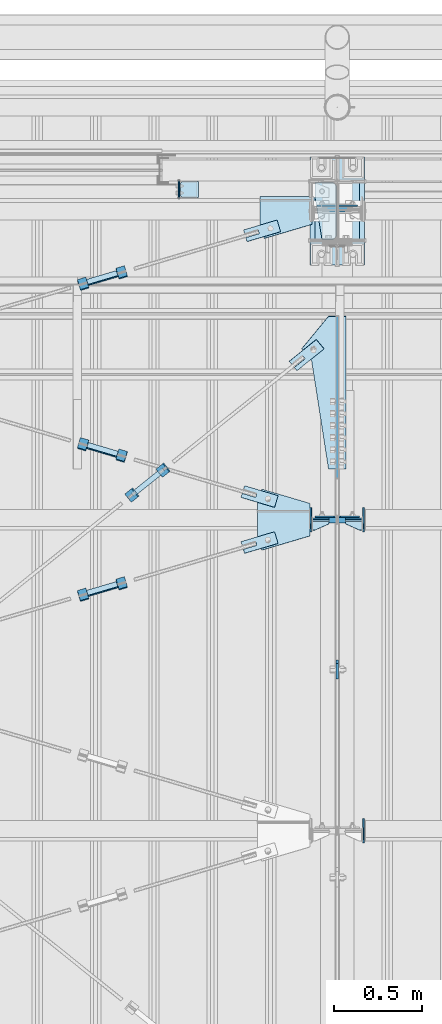
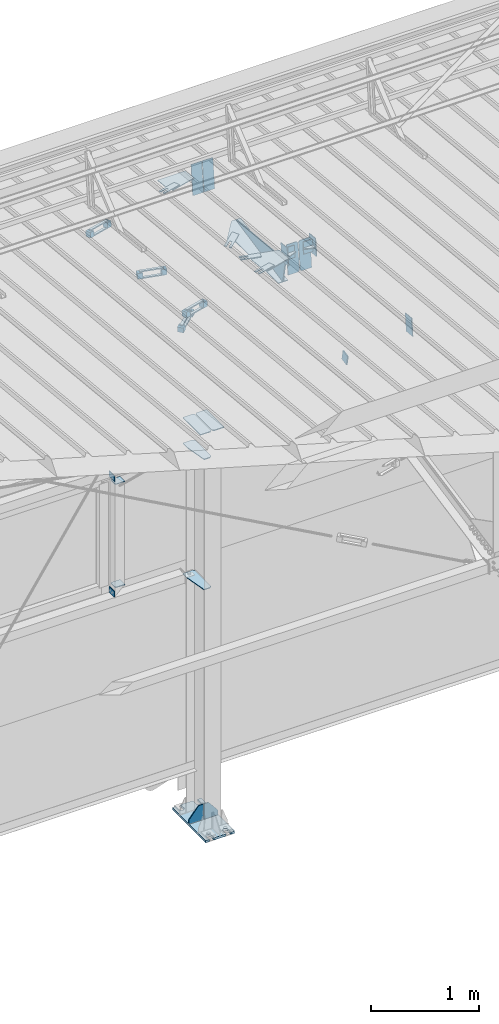
# One storey, part 135 of 709: 47 plates, 7 openings, 18 elements without a shape of their own.
"""IFC4 building model written with IfcOpenShell, lengths in millimetres."""

from ifc_helpers import new_model, si_unit, direction, frame, origin_with_axes, place, context, subcontext, project, spatial, line, arc, indexed_curve, outline, extrude, material, element, aggregate, save


model = new_model("IFC4")

# Units and contexts
model_context = context("Model", 3, precision=0.2, world=origin_with_axes(), true_north=direction((0.0, 1.0)))
body_context = subcontext(model_context, "Body", "Model", "MODEL_VIEW")
ifc_project = project(units=[si_unit("LENGTHUNIT", "METRE", prefix="MILLI"), si_unit("AREAUNIT", "SQUARE_METRE"), si_unit("VOLUMEUNIT", "CUBIC_METRE"), si_unit("MASSUNIT", "GRAM", prefix="KILO"), si_unit("TIMEUNIT", "SECOND"), si_unit("PLANEANGLEUNIT", "RADIAN"), si_unit("SOLIDANGLEUNIT", "STERADIAN"), si_unit("THERMODYNAMICTEMPERATUREUNIT", "DEGREE_CELSIUS"), si_unit("LUMINOUSINTENSITYUNIT", "LUMEN")], contexts=[model_context])

# Site, building, storey
site_placement = place(None, origin_with_axes())
site = spatial("IfcSite", under=ifc_project, at=site_placement, CompositionType="ELEMENT")
building_placement = place(site_placement, origin_with_axes())
building = spatial("IfcBuilding", under=site, at=building_placement, Name="Undefined", CompositionType="ELEMENT")
storey_placement = place(building_placement, origin_with_axes())
storey = spatial("IfcBuildingStorey", under=building, at=storey_placement, Name="Undefined", CompositionType="ELEMENT", Elevation=0.0)

# Assembly, plates, voiding features
assembly_1_placement = place(storey_placement, frame((10000.0, 21827.0, -200.0), z_axis=(-1.0, 0.0, 0.0), x_axis=(0.0, 0.0, 1.0)))
assembly_1 = element("IfcElementAssembly", 1, at=assembly_1_placement, inside=storey)
ifc_material_1 = material(Name="C355-6", Category="STEEL")
plate_1_placement = place(assembly_1_placement, frame((7434.21546, 30.02526, -3.0), z_axis=(-0.099503719, 0.9950371902, 0.0), x_axis=(0.0, 0.0, -1.0)))
plate_1 = element("IfcPlate", 2, at=plate_1_placement, material=ifc_material_1, ObjectType="595", context=body_context, shape_type="SolidModel", body=[
    extrude(outline(indexed_curve([(0.0, 0.0), (114.0, 0.0), (114.0, 333.33554), (0.0, 333.33554)], segments=[line(1, 2, 3, 4, 1)])), frame((0.0, 0.0, 4.0), z_axis=(0.0, 0.0, 1.0), x_axis=(1.0, 0.0, 0.0)), (0.0, 0.0, -1.0), 8.0),
])
plate_2_placement = place(assembly_1_placement, frame((7434.21546, 30.02526, 3.0), z_axis=(0.099503719, -0.9950371902, 0.0), x_axis=(0.0, 0.0, 1.0)))
plate_2 = element("IfcPlate", 3, at=plate_2_placement, material=ifc_material_1, ObjectType="595", context=body_context, shape_type="SolidModel", body=[
    extrude(outline(indexed_curve([(0.0, 0.0), (114.0, 0.0), (114.0, 332.53554), (0.0, 332.53554)], segments=[line(1, 2, 3, 4, 1)])), frame((0.0, 0.0, 4.0), z_axis=(0.0, 0.0, 1.0), x_axis=(1.0, 0.0, 0.0)), (0.0, 0.0, -1.0), 8.0),
])
plate_3_placement = place(assembly_1_placement, frame((4212.0, 163.0, 4.0), z_axis=(1.0, 0.0, 0.0), x_axis=(0.0, 0.0, 1.0)))
plate_3 = element("IfcPlate", 4, at=plate_3_placement, material=ifc_material_1, ObjectType="543", context=body_context, shape_type="SolidModel", body=[
    extrude(outline(indexed_curve([(0.0, 20.0), (20.0, 0.0), (123.0, 0.0), (123.0, 86.0), (83.0, 326.0), (20.0, 326.0), (0.0, 306.0)], segments=[line(1, 2, 3, 4, 5, 6, 7, 1)])), frame((0.0, 0.0, 4.0), z_axis=(0.0, 0.0, 1.0), x_axis=(1.0, 0.0, 0.0)), (0.0, 0.0, -1.0), 8.0),
])
plate_4_placement = place(assembly_1_placement, frame((4502.0, 163.0, 127.0), z_axis=(-1.0, 0.0, 0.0), x_axis=(0.0, 0.0, -1.0)))
plate_4 = element("IfcPlate", 5, at=plate_4_placement, material=ifc_material_1, ObjectType="547", context=body_context, shape_type="SolidModel", body=[
    extrude(outline(indexed_curve([(0.0, 0.0), (108.0, 0.0), (123.0, 15.0), (123.0, 311.0), (108.0, 326.0), (0.0, 326.0)], segments=[line(1, 2, 3, 4, 5, 6, 1)])), frame((0.0, 0.0, 4.0), z_axis=(0.0, 0.0, 1.0), x_axis=(1.0, 0.0, 0.0)), (0.0, 0.0, -1.0), 8.0),
])
plate_5_placement = place(assembly_1_placement, frame((2742.0, 163.0, 4.0), z_axis=(1.0, 0.0, 0.0), x_axis=(0.0, 0.0, 1.0)))
plate_5 = element("IfcPlate", 6, at=plate_5_placement, material=ifc_material_1, ObjectType="543", context=body_context, shape_type="SolidModel", body=[
    extrude(outline(indexed_curve([(0.0, 20.0), (20.0, 0.0), (123.0, 0.0), (123.0, 86.0), (83.0, 326.0), (20.0, 326.0), (0.0, 306.0)], segments=[line(1, 2, 3, 4, 5, 6, 7, 1)])), frame((0.0, 0.0, 4.0), z_axis=(0.0, 0.0, 1.0), x_axis=(1.0, 0.0, 0.0)), (0.0, 0.0, -1.0), 8.0),
])
plate_6_placement = place(assembly_1_placement, frame((4502.0, -163.0, -127.0), z_axis=(-1.0, 0.0, 0.0), x_axis=(0.0, 0.0, 1.0)))
plate_6 = element("IfcPlate", 7, at=plate_6_placement, material=ifc_material_1, ObjectType="547", context=body_context, shape_type="SolidModel", body=[
    extrude(outline(indexed_curve([(0.0, 0.0), (108.0, 0.0), (123.0, 15.0), (123.0, 311.0), (108.0, 326.0), (0.0, 326.0)], segments=[line(1, 2, 3, 4, 5, 6, 1)])), frame((0.0, 0.0, 4.0), z_axis=(0.0, 0.0, 1.0), x_axis=(1.0, 0.0, 0.0)), (0.0, 0.0, -1.0), 8.0),
])
plate_7_placement = place(assembly_1_placement, frame((25.0, 0.0, 3.0), z_axis=(0.0, 1.0, 0.0), x_axis=(0.0, 0.0, 1.0)))
plate_7 = element("IfcPlate", 8, at=plate_7_placement, material=ifc_material_1, ObjectType="417", context=body_context, shape_type="SolidModel", body=[
    extrude(outline(indexed_curve([(0.0, 0.0), (152.0, 0.0), (152.0, 50.0), (50.0, 175.0), (0.0, 175.0)], segments=[line(1, 2, 3, 4, 5, 1)])), frame((0.0, 0.0, 4.0), z_axis=(0.0, 0.0, 1.0), x_axis=(1.0, 0.0, 0.0)), (0.0, 0.0, -1.0), 8.0),
])
plate_8_placement = place(assembly_1_placement, frame((25.0, 0.0, -3.0), z_axis=(0.0, -1.0, 0.0), x_axis=(0.0, 0.0, -1.0)))
plate_8 = element("IfcPlate", 9, at=plate_8_placement, material=ifc_material_1, ObjectType="417", context=body_context, shape_type="SolidModel", body=[
    extrude(outline(indexed_curve([(0.0, 0.0), (152.0, 0.0), (152.0, 50.0), (50.0, 175.0), (0.0, 175.0)], segments=[line(1, 2, 3, 4, 5, 1)])), frame((0.0, 0.0, 4.0), z_axis=(0.0, 0.0, 1.0), x_axis=(1.0, 0.0, 0.0)), (0.0, 0.0, -1.0), 8.0),
])
plate_9_placement = place(assembly_1_placement, frame((12.5, -308.0, 155.0), z_axis=(1.0, 0.0, 0.0), x_axis=(0.0, 0.0, -1.0)))
plate_9 = element("IfcPlate", 10, at=plate_9_placement, material=ifc_material_1, ObjectType="416", context=body_context, shape_type="SolidModel", body=[
    extrude(outline(indexed_curve([(0.0, 0.0), (310.0, 0.0), (310.0, 616.0), (0.0, 616.0)], segments=[line(1, 2, 3, 4, 1)])), frame((0.0, 0.0, 12.5), z_axis=(0.0, 0.0, 1.0), x_axis=(1.0, 0.0, 0.0)), (0.0, 0.0, -1.0), 25.0),
])
voiding_feature_1_placement = place(plate_9_placement, frame((40.0, 616.0, 0.0), z_axis=(0.0, 0.0, -1.0), x_axis=(1.0, 0.0, 0.0)))
element("IfcVoidingFeature", 11, at=voiding_feature_1_placement, cuts=plate_9, PredefinedType="HOLE", context=body_context, shape_type="SolidModel", body=[
    extrude(outline(indexed_curve([(0.0, 0.0), (50.0, 0.0), (50.0, 60.0), (42.67767, 77.67767), (25.0, 85.0), (25.0, 85.0), (7.32233, 77.67767), (0.0, 60.0)], segments=[line(1, 2, 3), arc(3, 4, 5), line(5, 6), arc(6, 7, 8), line(8, 1)])), frame((0.0, 0.0, 12.5), z_axis=(0.0, 0.0, 1.0), x_axis=(1.0, 0.0, 0.0)), (0.0, 0.0, -1.0), 25.0),
])
voiding_feature_2_placement = place(plate_9_placement, frame((40.0, 0.0, 0.0), z_axis=(0.0, 0.0, 1.0), x_axis=(1.0, 0.0, 0.0)))
element("IfcVoidingFeature", 12, at=voiding_feature_2_placement, cuts=plate_9, PredefinedType="HOLE", context=body_context, shape_type="SolidModel", body=[
    extrude(outline(indexed_curve([(0.0, 0.0), (50.0, 0.0), (50.0, 60.0), (42.67767, 77.67767), (25.0, 85.0), (25.0, 85.0), (7.32233, 77.67767), (0.0, 60.0)], segments=[line(1, 2, 3), arc(3, 4, 5), line(5, 6), arc(6, 7, 8), line(8, 1)])), frame((0.0, 0.0, 12.5), z_axis=(0.0, 0.0, 1.0), x_axis=(1.0, 0.0, 0.0)), (0.0, 0.0, -1.0), 25.0),
])
voiding_feature_3_placement = place(plate_9_placement, frame((270.0, 616.0, 0.0), z_axis=(0.0, 0.0, 1.0), x_axis=(-1.0, 0.0, 0.0)))
element("IfcVoidingFeature", 13, at=voiding_feature_3_placement, cuts=plate_9, PredefinedType="HOLE", context=body_context, shape_type="SolidModel", body=[
    extrude(outline(indexed_curve([(0.0, 0.0), (50.0, 0.0), (50.0, 60.0), (42.67767, 77.67767), (25.0, 85.0), (25.0, 85.0), (7.32233, 77.67767), (0.0, 60.0)], segments=[line(1, 2, 3), arc(3, 4, 5), line(5, 6), arc(6, 7, 8), line(8, 1)])), frame((0.0, 0.0, 12.5), z_axis=(0.0, 0.0, 1.0), x_axis=(1.0, 0.0, 0.0)), (0.0, 0.0, -1.0), 25.0),
])
voiding_feature_4_placement = place(plate_9_placement, frame((270.0, 0.0, 0.0), z_axis=(0.0, 0.0, -1.0), x_axis=(-1.0, 0.0, 0.0)))
element("IfcVoidingFeature", 14, at=voiding_feature_4_placement, cuts=plate_9, PredefinedType="HOLE", context=body_context, shape_type="SolidModel", body=[
    extrude(outline(indexed_curve([(0.0, 0.0), (50.0, 0.0), (50.0, 60.0), (42.67767, 77.67767), (25.0, 85.0), (25.0, 85.0), (7.32233, 77.67767), (0.0, 60.0)], segments=[line(1, 2, 3), arc(3, 4, 5), line(5, 6), arc(6, 7, 8), line(8, 1)])), frame((0.0, 0.0, 12.5), z_axis=(0.0, 0.0, 1.0), x_axis=(1.0, 0.0, 0.0)), (0.0, 0.0, -1.0), 25.0),
])
aggregate(assembly_1, [plate_1, plate_2, plate_3, plate_4, plate_5, plate_6, plate_7, plate_8, plate_9])

# Assembly, plates
assembly_2_placement = place(storey_placement, frame((10000.0, 21654.0, 7089.70002), z_axis=(-1.0, 0.0, 0.0), x_axis=(0.0, -0.9950371902, 0.099503719)))
assembly_2 = element("IfcElementAssembly", 15, at=assembly_2_placement, inside=storey)
plate_10_placement = place(assembly_2_placement, frame((1597.88359, 163.0, -127.0), z_axis=(1.0, 0.0, 0.0), x_axis=(0.0, 0.0, 1.0)))
plate_10 = element("IfcPlate", 16, at=plate_10_placement, material=ifc_material_1, ObjectType="585", context=body_context, shape_type="SolidModel", body=[
    extrude(outline(indexed_curve([(0.0, 0.0), (108.0, 0.0), (123.0, 15.0), (123.0, 311.0), (108.0, 326.0), (0.0, 326.0)], segments=[line(1, 2, 3, 4, 5, 6, 1)])), frame((0.0, 0.0, 4.0), z_axis=(0.0, 0.0, 1.0), x_axis=(1.0, 0.0, 0.0)), (0.0, 0.0, -1.0), 8.0),
])
plate_11_placement = place(assembly_2_placement, frame((1597.88359, 163.0, 127.0), z_axis=(-1.0, 0.0, 0.0), x_axis=(0.0, 0.0, -1.0)))
plate_11 = element("IfcPlate", 17, at=plate_11_placement, material=ifc_material_1, ObjectType="585", context=body_context, shape_type="SolidModel", body=[
    extrude(outline(indexed_curve([(0.0, 0.0), (108.0, 0.0), (123.0, 15.0), (123.0, 311.0), (108.0, 326.0), (0.0, 326.0)], segments=[line(1, 2, 3, 4, 5, 6, 1)])), frame((0.0, 0.0, 4.0), z_axis=(0.0, 0.0, 1.0), x_axis=(1.0, 0.0, 0.0)), (0.0, 0.0, -1.0), 8.0),
])
plate_12_placement = place(assembly_2_placement, frame((1342.111, -173.0, 0.0), z_axis=(0.0, 0.0, 1.0), x_axis=(-1.0, 0.0, 0.0)))
plate_12 = element("IfcPlate", 18, at=plate_12_placement, material=ifc_material_1, ObjectType="449", context=body_context, shape_type="SolidModel", body=[
    extrude(outline(indexed_curve([(0.0, 0.0), (928.3198, 0.0), (79.53997, 259.83056)], segments=[line(1, 2, 3, 1)])), frame((0.0, 0.0, 6.0), z_axis=(0.0, 0.0, 1.0), x_axis=(1.0, 0.0, 0.0)), (0.0, 0.0, -1.0), 12.0),
])
plate_13_placement = place(assembly_2_placement, frame((1261.40018, -436.65536, -50.0), z_axis=(0.2927142719, 0.9561999556, 0.0), x_axis=(-0.9561999556, 0.2927142719, 0.0)))
plate_13 = element("IfcPlate", 19, at=plate_13_placement, material=ifc_material_1, ObjectType="489", context=body_context, shape_type="SolidModel", body=[
    extrude(outline(indexed_curve([(0.0, 0.0), (887.65935, 0.0), (887.65935, 100.0), (698.2863, 253.1922), (628.6057, 196.23068), (0.0, 100.0)], segments=[line(1, 2, 3, 4, 5, 6, 1)])), frame((0.0, 0.0, 4.0), z_axis=(0.0, 0.0, 1.0), x_axis=(1.0, 0.0, 0.0)), (0.0, 0.0, -1.0), 8.0),
])
aggregate(assembly_2, [plate_10, plate_11, plate_12, plate_13])

# Assembly, plate
assembly_3_placement = place(storey_placement, frame((8916.07962, 20275.59044, 6772.92001), z_axis=(0.625451877, -0.7802627439, 1e-10), x_axis=(0.7742288439, 0.6206151549, 0.124123031)))
assembly_3 = element("IfcElementAssembly", 20, at=assembly_3_placement, inside=storey)
plate_14_placement = place(assembly_3_placement, frame((1074.34134, 5.35577, -34.5878), z_axis=(0.0, -0.9882227648, -0.1530221131), x_axis=(1.0, 0.0, 0.0)))
plate_14 = element("IfcPlate", 21, at=plate_14_placement, material=ifc_material_1, ObjectType="490", context=body_context, shape_type="SolidModel", body=[
    extrude(outline(indexed_curve([(0.0, 0.0), (200.0, 0.0), (200.0, 70.0), (0.0, 70.0), (0.0, 46.0), (80.0, 46.0), (80.0, 24.0), (0.0, 24.0)], segments=[line(1, 2, 3, 4, 5, 6, 7, 8, 1)])), frame((0.0, 0.0, 4.0), z_axis=(0.0, 0.0, 1.0), x_axis=(1.0, 0.0, 0.0)), (0.0, 0.0, -1.0), 8.0),
])
aggregate(assembly_3, [plate_14])

# Assembly, plates
assembly_4_placement = place(storey_placement, frame((9020.97403, 20321.22431, 6816.96217), z_axis=(-0.7742288439, -0.6206151548, -0.1241230313), x_axis=(-0.625451877, 0.780262744, 0.0)))
assembly_4 = element("IfcElementAssembly", 22, at=assembly_4_placement, inside=storey)
ifc_material_2 = material(Name="Steel_Undefined", Category="STEEL")
plate_15_placement = place(assembly_4_placement, origin_with_axes())
plate_15 = element("IfcPlate", 23, at=plate_15_placement, material=ifc_material_2, ObjectType="482", context=body_context, shape_type="SolidModel", body=[
    extrude(outline(indexed_curve([(0.0, 0.0), (60.0, 0.0), (60.0, 60.0), (0.0, 60.0)], segments=[line(1, 2, 3, 4, 1)])), frame((0.0, 0.0, 25.0), z_axis=(0.0, 0.0, 1.0), x_axis=(1.0, 0.0, 0.0)), (0.0, 0.0, -1.0), 50.0),
])
plate_16_placement = place(assembly_4_placement, frame((15.0, -6.0, 230.0), z_axis=(0.0, 1.0, 0.0), x_axis=(1.0, 0.0, 0.0)))
plate_16 = element("IfcPlate", 24, at=plate_16_placement, material=ifc_material_2, ObjectType="484", context=body_context, shape_type="SolidModel", body=[
    extrude(outline(indexed_curve([(0.0, 0.0), (30.0, 0.0), (30.0, 230.0), (0.0, 230.0)], segments=[line(1, 2, 3, 4, 1)])), frame((0.0, 0.0, 6.0), z_axis=(0.0, 0.0, 1.0), x_axis=(1.0, 0.0, 0.0)), (0.0, 0.0, -1.0), 12.0),
])
plate_17_placement = place(assembly_4_placement, frame((0.0, 0.0, 230.0), z_axis=(0.0, 0.0, 1.0), x_axis=(1.0, 0.0, 0.0)))
plate_17 = element("IfcPlate", 25, at=plate_17_placement, material=ifc_material_2, ObjectType="483", context=body_context, shape_type="SolidModel", body=[
    extrude(outline(indexed_curve([(0.0, 0.0), (60.0, 0.0), (60.0, 60.0), (0.0, 60.0)], segments=[line(1, 2, 3, 4, 1)])), frame((0.0, 0.0, 25.0), z_axis=(0.0, 0.0, 1.0), x_axis=(1.0, 0.0, 0.0)), (0.0, 0.0, -1.0), 50.0),
])
plate_18_placement = place(assembly_4_placement, frame((15.0, 66.0, 230.0), z_axis=(0.0, 1.0, 0.0), x_axis=(1.0, 0.0, 0.0)))
plate_18 = element("IfcPlate", 26, at=plate_18_placement, material=ifc_material_2, ObjectType="484", context=body_context, shape_type="SolidModel", body=[
    extrude(outline(indexed_curve([(0.0, 0.0), (30.0, 0.0), (30.0, 230.0), (0.0, 230.0)], segments=[line(1, 2, 3, 4, 1)])), frame((0.0, 0.0, 6.0), z_axis=(0.0, 0.0, 1.0), x_axis=(1.0, 0.0, 0.0)), (0.0, 0.0, -1.0), 12.0),
])
aggregate(assembly_4, [plate_15, plate_16, plate_17, plate_18])

# Assembly, plate
assembly_5_placement = place(storey_placement, frame((10000.0, 19241.53388, 6684.40595), z_axis=(1.0, 0.0, 0.0), x_axis=(0.0, -0.9805806757, -0.1961161349)))
assembly_5 = element("IfcElementAssembly", 27, at=assembly_5_placement, inside=storey)
plate_19_placement = place(assembly_5_placement, origin_with_axes())
plate_19 = element("IfcPlate", 28, at=plate_19_placement, material=ifc_material_1, ObjectType="491", context=body_context, shape_type="SolidModel", body=[
    extrude(outline(indexed_curve([(0.0, 0.0), (90.0, 0.0), (90.0, 110.0), (0.0, 110.0)], segments=[line(1, 2, 3, 4, 1)])), frame((0.0, 0.0, 6.0), z_axis=(0.0, 0.0, 1.0), x_axis=(1.0, 0.0, 0.0)), (0.0, 0.0, -1.0), 12.0),
])
aggregate(assembly_5, [plate_19])

assembly_6_placement = place(storey_placement, frame((10000.0, 21950.0, 2550.0), z_axis=(0.0, 0.0, -1.0), x_axis=(-1.0, 0.0, 0.0)))
assembly_6 = element("IfcElementAssembly", 29, at=assembly_6_placement, inside=storey)
plate_20_placement = place(assembly_6_placement, frame((904.0, 50.0, -50.0), z_axis=(-1.0, 0.0, 0.0), x_axis=(0.0, 0.0, -1.0)))
plate_20 = element("IfcPlate", 30, at=plate_20_placement, material=ifc_material_1, ObjectType="509", context=body_context, shape_type="SolidModel", body=[
    extrude(outline(indexed_curve([(0.0, 0.0), (65.0, 0.0), (65.0, 100.0), (0.0, 100.0)], segments=[line(1, 2, 3, 4, 1)])), frame((0.0, 0.0, 4.0), z_axis=(0.0, 0.0, 1.0), x_axis=(1.0, 0.0, 0.0)), (0.0, 0.0, -1.0), 8.0),
])
aggregate(assembly_6, [plate_20])

assembly_7_placement = place(storey_placement, frame((10000.0, 21950.0, 4020.0), z_axis=(0.0, 0.0, -1.0), x_axis=(-1.0, 0.0, 0.0)))
assembly_7 = element("IfcElementAssembly", 31, at=assembly_7_placement, inside=storey)
plate_21_placement = place(assembly_7_placement, frame((904.0, -50.0, 50.0), z_axis=(-1.0, 0.0, 0.0), x_axis=(0.0, 0.0, 1.0)))
plate_21 = element("IfcPlate", 32, at=plate_21_placement, material=ifc_material_1, ObjectType="509", context=body_context, shape_type="SolidModel", body=[
    extrude(outline(indexed_curve([(0.0, 0.0), (65.0, 0.0), (65.0, 100.0), (0.0, 100.0)], segments=[line(1, 2, 3, 4, 1)])), frame((0.0, 0.0, 4.0), z_axis=(0.0, 0.0, 1.0), x_axis=(1.0, 0.0, 0.0)), (0.0, 0.0, -1.0), 8.0),
])
aggregate(assembly_7, [plate_21])

# Assembly, plates
assembly_8_placement = place(storey_placement, frame((9150.0, 21950.0, 2600.0), z_axis=(-1.0, 0.0, 0.0), x_axis=(0.0, 0.0, 1.0)))
assembly_8 = element("IfcElementAssembly", 33, at=assembly_8_placement, inside=storey)
plate_22_placement = place(assembly_8_placement, frame((1267.0, 46.0, 46.0), z_axis=(1.0, 0.0, 0.0), x_axis=(0.0, -1.0, 0.0)))
plate_22 = element("IfcPlate", 34, at=plate_22_placement, material=ifc_material_1, ObjectType="510", context=body_context, shape_type="SolidModel", body=[
    extrude(outline(indexed_curve([(0.0, 10.0), (10.0, 0.0), (82.0, 0.0), (92.0, 10.0), (92.0, 104.0), (0.0, 104.0)], segments=[line(1, 2, 3, 4, 5, 6, 1)])), frame((0.0, 0.0, 4.0), z_axis=(0.0, 0.0, 1.0), x_axis=(1.0, 0.0, 0.0)), (0.0, 0.0, -1.0), 8.0),
])
plate_23_placement = place(assembly_8_placement, frame((103.0, -46.0, 46.0), z_axis=(-1.0, 0.0, 0.0), x_axis=(0.0, 1.0, 0.0)))
plate_23 = element("IfcPlate", 35, at=plate_23_placement, material=ifc_material_1, ObjectType="510", context=body_context, shape_type="SolidModel", body=[
    extrude(outline(indexed_curve([(0.0, 10.0), (10.0, 0.0), (82.0, 0.0), (92.0, 10.0), (92.0, 104.0), (0.0, 104.0)], segments=[line(1, 2, 3, 4, 5, 6, 1)])), frame((0.0, 0.0, 4.0), z_axis=(0.0, 0.0, 1.0), x_axis=(1.0, 0.0, 0.0)), (0.0, 0.0, -1.0), 8.0),
])
aggregate(assembly_8, [plate_22, plate_23])

# Assembly, plate, voiding feature
assembly_9_placement = place(storey_placement, frame((8658.15773, 19666.8041, 7369.82361), z_axis=(0.2852311229, -0.9537021177, 0.0953702118), x_axis=(0.9584587662, 0.2838155751, -0.028381558)))
assembly_9 = element("IfcElementAssembly", 36, at=assembly_9_placement, inside=storey)
plate_24_placement = place(assembly_9_placement, frame((1036.9749, 0.0, 35.0), z_axis=(0.0, 1.0, 0.0), x_axis=(0.0, 0.0, -1.0)))
plate_24 = element("IfcPlate", 37, at=plate_24_placement, material=ifc_material_1, ObjectType="574", context=body_context, shape_type="SolidModel", body=[
    extrude(outline(indexed_curve([(0.0, 0.0), (70.0, 0.0), (70.0, 200.0), (0.0, 200.0)], segments=[line(1, 2, 3, 4, 1)])), frame((0.0, 0.0, 4.0), z_axis=(0.0, 0.0, 1.0), x_axis=(1.0, 0.0, 0.0)), (0.0, 0.0, -1.0), 8.0),
])
voiding_feature_5_placement = place(plate_24_placement, frame((24.0, 120.0, 0.0), z_axis=(0.0, 0.0, 1.0), x_axis=(1.0, 0.0, 0.0)))
element("IfcVoidingFeature", 38, at=voiding_feature_5_placement, cuts=plate_24, Name="PLATE", PredefinedType="HOLE", context=body_context, shape_type="SolidModel", body=[
    extrude(outline(indexed_curve([(0.0, 0.0), (22.0, 0.0), (22.0, 85.0), (0.0, 85.0)], segments=[line(1, 2, 3, 4, 1)])), frame((0.0, 0.0, 6.5), z_axis=(0.0, 0.0, 1.0), x_axis=(1.0, 0.0, 0.0)), (0.0, 0.0, -1.0), 13.0),
])
aggregate(assembly_9, [plate_24])

# Assembly, plates
assembly_10_placement = place(storey_placement, frame((8776.93742, 19673.81694, 7399.27195), z_axis=(-0.9584587662, -0.2838155751, 0.0283815575), x_axis=(-0.2852311229, 0.9537021176, -0.095370212)))
assembly_10 = element("IfcElementAssembly", 39, at=assembly_10_placement, inside=storey)
plate_25_placement = place(assembly_10_placement, frame((15.0, -6.0, 230.0), z_axis=(0.0, 1.0, 0.0), x_axis=(1.0, 0.0, 0.0)))
plate_25 = element("IfcPlate", 40, at=plate_25_placement, material=ifc_material_2, ObjectType="484", context=body_context, shape_type="SolidModel", body=[
    extrude(outline(indexed_curve([(0.0, 0.0), (30.0, 0.0), (30.0, 230.0), (0.0, 230.0)], segments=[line(1, 2, 3, 4, 1)])), frame((0.0, 0.0, 6.0), z_axis=(0.0, 0.0, 1.0), x_axis=(1.0, 0.0, 0.0)), (0.0, 0.0, -1.0), 12.0),
])
plate_26_placement = place(assembly_10_placement, frame((0.0, 0.0, 230.0), z_axis=(0.0, 0.0, 1.0), x_axis=(1.0, 0.0, 0.0)))
plate_26 = element("IfcPlate", 41, at=plate_26_placement, material=ifc_material_2, ObjectType="483", context=body_context, shape_type="SolidModel", body=[
    extrude(outline(indexed_curve([(0.0, 0.0), (60.0, 0.0), (60.0, 60.0), (0.0, 60.0)], segments=[line(1, 2, 3, 4, 1)])), frame((0.0, 0.0, 25.0), z_axis=(0.0, 0.0, 1.0), x_axis=(1.0, 0.0, 0.0)), (0.0, 0.0, -1.0), 50.0),
])
plate_27_placement = place(assembly_10_placement, frame((15.0, 66.0, 230.0), z_axis=(0.0, 1.0, 0.0), x_axis=(1.0, 0.0, 0.0)))
plate_27 = element("IfcPlate", 42, at=plate_27_placement, material=ifc_material_2, ObjectType="484", context=body_context, shape_type="SolidModel", body=[
    extrude(outline(indexed_curve([(0.0, 0.0), (30.0, 0.0), (30.0, 230.0), (0.0, 230.0)], segments=[line(1, 2, 3, 4, 1)])), frame((0.0, 0.0, 6.0), z_axis=(0.0, 0.0, 1.0), x_axis=(1.0, 0.0, 0.0)), (0.0, 0.0, -1.0), 12.0),
])
plate_28_placement = place(assembly_10_placement, origin_with_axes())
plate_28 = element("IfcPlate", 43, at=plate_28_placement, material=ifc_material_2, ObjectType="482", context=body_context, shape_type="SolidModel", body=[
    extrude(outline(indexed_curve([(0.0, 0.0), (60.0, 0.0), (60.0, 60.0), (0.0, 60.0)], segments=[line(1, 2, 3, 4, 1)])), frame((0.0, 0.0, 25.0), z_axis=(0.0, 0.0, 1.0), x_axis=(1.0, 0.0, 0.0)), (0.0, 0.0, -1.0), 50.0),
])
aggregate(assembly_10, [plate_25, plate_26, plate_27, plate_28])

# Assembly, plate, voiding feature
assembly_11_placement = place(storey_placement, frame((8658.15773, 21443.50385, 7192.15363), z_axis=(0.2852311229, -0.9537021177, 0.0953702118), x_axis=(0.9584587662, 0.2838155751, -0.028381558)))
assembly_11 = element("IfcElementAssembly", 44, at=assembly_11_placement, inside=storey)
plate_29_placement = place(assembly_11_placement, frame((1051.9749, 0.0, 35.0), z_axis=(0.0, 1.0, 0.0), x_axis=(0.0, 0.0, -1.0)))
plate_29 = element("IfcPlate", 45, at=plate_29_placement, material=ifc_material_1, ObjectType="574", context=body_context, shape_type="SolidModel", body=[
    extrude(outline(indexed_curve([(0.0, 0.0), (70.0, 0.0), (70.0, 200.0), (0.0, 200.0)], segments=[line(1, 2, 3, 4, 1)])), frame((0.0, 0.0, 4.0), z_axis=(0.0, 0.0, 1.0), x_axis=(1.0, 0.0, 0.0)), (0.0, 0.0, -1.0), 8.0),
])
voiding_feature_6_placement = place(plate_29_placement, frame((24.0, 120.0, 0.0), z_axis=(0.0, 0.0, 1.0), x_axis=(1.0, 0.0, 0.0)))
element("IfcVoidingFeature", 46, at=voiding_feature_6_placement, cuts=plate_29, Name="PLATE", PredefinedType="HOLE", context=body_context, shape_type="SolidModel", body=[
    extrude(outline(indexed_curve([(0.0, 0.0), (22.0, 0.0), (22.0, 85.0), (0.0, 85.0)], segments=[line(1, 2, 3, 4, 1)])), frame((0.0, 0.0, 6.5), z_axis=(0.0, 0.0, 1.0), x_axis=(1.0, 0.0, 0.0)), (0.0, 0.0, -1.0), 13.0),
])
aggregate(assembly_11, [plate_29])

# Assembly, plates
assembly_12_placement = place(storey_placement, frame((8776.93742, 21450.51669, 7221.60197), z_axis=(-0.9584587662, -0.2838155751, 0.0283815575), x_axis=(-0.2852311229, 0.9537021176, -0.095370212)))
assembly_12 = element("IfcElementAssembly", 47, at=assembly_12_placement, inside=storey)
plate_30_placement = place(assembly_12_placement, origin_with_axes())
plate_30 = element("IfcPlate", 48, at=plate_30_placement, material=ifc_material_2, ObjectType="482", context=body_context, shape_type="SolidModel", body=[
    extrude(outline(indexed_curve([(0.0, 0.0), (60.0, 0.0), (60.0, 60.0), (0.0, 60.0)], segments=[line(1, 2, 3, 4, 1)])), frame((0.0, 0.0, 25.0), z_axis=(0.0, 0.0, 1.0), x_axis=(1.0, 0.0, 0.0)), (0.0, 0.0, -1.0), 50.0),
])
plate_31_placement = place(assembly_12_placement, frame((15.0, 66.0, 230.0), z_axis=(0.0, 1.0, 0.0), x_axis=(1.0, 0.0, 0.0)))
plate_31 = element("IfcPlate", 49, at=plate_31_placement, material=ifc_material_2, ObjectType="484", context=body_context, shape_type="SolidModel", body=[
    extrude(outline(indexed_curve([(0.0, 0.0), (30.0, 0.0), (30.0, 230.0), (0.0, 230.0)], segments=[line(1, 2, 3, 4, 1)])), frame((0.0, 0.0, 6.0), z_axis=(0.0, 0.0, 1.0), x_axis=(1.0, 0.0, 0.0)), (0.0, 0.0, -1.0), 12.0),
])
plate_32_placement = place(assembly_12_placement, frame((0.0, 0.0, 230.0), z_axis=(0.0, 0.0, 1.0), x_axis=(1.0, 0.0, 0.0)))
plate_32 = element("IfcPlate", 50, at=plate_32_placement, material=ifc_material_2, ObjectType="483", context=body_context, shape_type="SolidModel", body=[
    extrude(outline(indexed_curve([(0.0, 0.0), (60.0, 0.0), (60.0, 60.0), (0.0, 60.0)], segments=[line(1, 2, 3, 4, 1)])), frame((0.0, 0.0, 25.0), z_axis=(0.0, 0.0, 1.0), x_axis=(1.0, 0.0, 0.0)), (0.0, 0.0, -1.0), 50.0),
])
plate_33_placement = place(assembly_12_placement, frame((15.0, -6.0, 230.0), z_axis=(0.0, 1.0, 0.0), x_axis=(1.0, 0.0, 0.0)))
plate_33 = element("IfcPlate", 51, at=plate_33_placement, material=ifc_material_2, ObjectType="484", context=body_context, shape_type="SolidModel", body=[
    extrude(outline(indexed_curve([(0.0, 0.0), (30.0, 0.0), (30.0, 230.0), (0.0, 230.0)], segments=[line(1, 2, 3, 4, 1)])), frame((0.0, 0.0, 6.0), z_axis=(0.0, 0.0, 1.0), x_axis=(1.0, 0.0, 0.0)), (0.0, 0.0, -1.0), 12.0),
])
aggregate(assembly_12, [plate_30, plate_31, plate_32, plate_33])

# Assembly, plate, voiding feature
assembly_13_placement = place(storey_placement, frame((8658.15773, 20461.48771, 7290.35524), z_axis=(-0.2852311229, -0.9537021177, 0.0953702118), x_axis=(0.9584587662, -0.2838155751, 0.028381558)))
assembly_13 = element("IfcElementAssembly", 52, at=assembly_13_placement, inside=storey)
plate_34_placement = place(assembly_13_placement, frame((1036.9749, 0.0, 35.0), z_axis=(0.0, 1.0, 0.0), x_axis=(0.0, 0.0, -1.0)))
plate_34 = element("IfcPlate", 53, at=plate_34_placement, material=ifc_material_1, ObjectType="574", context=body_context, shape_type="SolidModel", body=[
    extrude(outline(indexed_curve([(0.0, 0.0), (70.0, 0.0), (70.0, 200.0), (0.0, 200.0)], segments=[line(1, 2, 3, 4, 1)])), frame((0.0, 0.0, 4.0), z_axis=(0.0, 0.0, 1.0), x_axis=(1.0, 0.0, 0.0)), (0.0, 0.0, -1.0), 8.0),
])
voiding_feature_7_placement = place(plate_34_placement, frame((24.0, 120.0, 0.0), z_axis=(0.0, 0.0, 1.0), x_axis=(1.0, 0.0, 0.0)))
element("IfcVoidingFeature", 54, at=voiding_feature_7_placement, cuts=plate_34, Name="PLATE", PredefinedType="HOLE", context=body_context, shape_type="SolidModel", body=[
    extrude(outline(indexed_curve([(0.0, 0.0), (22.0, 0.0), (22.0, 85.0), (0.0, 85.0)], segments=[line(1, 2, 3, 4, 1)])), frame((0.0, 0.0, 6.5), z_axis=(0.0, 0.0, 1.0), x_axis=(1.0, 0.0, 0.0)), (0.0, 0.0, -1.0), 13.0),
])
aggregate(assembly_13, [plate_34])

# Assembly, plates
assembly_14_placement = place(storey_placement, frame((8759.82355, 20403.22297, 7326.33135), z_axis=(-0.9584587662, 0.2838155751, -0.0283815575), x_axis=(0.2852311229, 0.9537021176, -0.095370212)))
assembly_14 = element("IfcElementAssembly", 55, at=assembly_14_placement, inside=storey)
plate_35_placement = place(assembly_14_placement, origin_with_axes())
plate_35 = element("IfcPlate", 56, at=plate_35_placement, material=ifc_material_2, ObjectType="482", context=body_context, shape_type="SolidModel", body=[
    extrude(outline(indexed_curve([(0.0, 0.0), (60.0, 0.0), (60.0, 60.0), (0.0, 60.0)], segments=[line(1, 2, 3, 4, 1)])), frame((0.0, 0.0, 25.0), z_axis=(0.0, 0.0, 1.0), x_axis=(1.0, 0.0, 0.0)), (0.0, 0.0, -1.0), 50.0),
])
plate_36_placement = place(assembly_14_placement, frame((15.0, 66.0, 230.0), z_axis=(0.0, 1.0, 0.0), x_axis=(1.0, 0.0, 0.0)))
plate_36 = element("IfcPlate", 57, at=plate_36_placement, material=ifc_material_2, ObjectType="484", context=body_context, shape_type="SolidModel", body=[
    extrude(outline(indexed_curve([(0.0, 0.0), (30.0, 0.0), (30.0, 230.0), (0.0, 230.0)], segments=[line(1, 2, 3, 4, 1)])), frame((0.0, 0.0, 6.0), z_axis=(0.0, 0.0, 1.0), x_axis=(1.0, 0.0, 0.0)), (0.0, 0.0, -1.0), 12.0),
])
plate_37_placement = place(assembly_14_placement, frame((0.0, 0.0, 230.0), z_axis=(0.0, 0.0, 1.0), x_axis=(1.0, 0.0, 0.0)))
plate_37 = element("IfcPlate", 58, at=plate_37_placement, material=ifc_material_2, ObjectType="483", context=body_context, shape_type="SolidModel", body=[
    extrude(outline(indexed_curve([(0.0, 0.0), (60.0, 0.0), (60.0, 60.0), (0.0, 60.0)], segments=[line(1, 2, 3, 4, 1)])), frame((0.0, 0.0, 25.0), z_axis=(0.0, 0.0, 1.0), x_axis=(1.0, 0.0, 0.0)), (0.0, 0.0, -1.0), 50.0),
])
plate_38_placement = place(assembly_14_placement, frame((15.0, -6.0, 230.0), z_axis=(0.0, 1.0, 0.0), x_axis=(1.0, 0.0, 0.0)))
plate_38 = element("IfcPlate", 59, at=plate_38_placement, material=ifc_material_2, ObjectType="484", context=body_context, shape_type="SolidModel", body=[
    extrude(outline(indexed_curve([(0.0, 0.0), (30.0, 0.0), (30.0, 230.0), (0.0, 230.0)], segments=[line(1, 2, 3, 4, 1)])), frame((0.0, 0.0, 6.0), z_axis=(0.0, 0.0, 1.0), x_axis=(1.0, 0.0, 0.0)), (0.0, 0.0, -1.0), 12.0),
])
aggregate(assembly_14, [plate_35, plate_36, plate_37, plate_38])

assembly_15_placement = place(storey_placement, frame((10000.0, 20063.34988, 7322.12913), z_axis=(0.0, -0.9950371902, 0.099503719), x_axis=(-1.0, 0.0, 0.0)))
assembly_15 = element("IfcElementAssembly", 60, at=assembly_15_placement, inside=storey)
plate_39_placement = place(assembly_15_placement, frame((47.0, 0.0, 60.0), z_axis=(0.0, 1.0, 0.0), x_axis=(1.0, 0.0, 0.0)))
plate_39 = element("IfcPlate", 61, at=plate_39_placement, material=ifc_material_1, ObjectType="588", context=body_context, shape_type="SolidModel", body=[
    extrude(outline(indexed_curve([(0.0, 36.0), (80.0, 0.0), (100.0, 0.0), (100.0, 56.0), (0.0, 56.0)], segments=[line(1, 2, 3, 4, 5, 1)])), frame((0.0, 0.0, 4.0), z_axis=(0.0, 0.0, 1.0), x_axis=(1.0, 0.0, 0.0)), (0.0, 0.0, -1.0), 8.0),
])
plate_40_placement = place(assembly_15_placement, frame((47.0, -65.0, 0.0), z_axis=(0.0, 0.0, 1.0), x_axis=(1.0, 0.0, 0.0)))
plate_40 = element("IfcPlate", 62, at=plate_40_placement, material=ifc_material_1, ObjectType="587", context=body_context, shape_type="SolidModel", body=[
    extrude(outline(indexed_curve([(0.0, 0.0), (100.0, 0.0), (100.0, 130.0), (0.0, 130.0)], segments=[line(1, 2, 3, 4, 1)])), frame((0.0, 0.0, 4.0), z_axis=(0.0, 0.0, 1.0), x_axis=(1.0, 0.0, 0.0)), (0.0, 0.0, -1.0), 8.0),
])
plate_41_placement = place(assembly_15_placement, frame((154.99945, 0.0, 93.07721), z_axis=(0.0, -1.0, 0.0), x_axis=(0.0, 0.0, -1.0)))
plate_41 = element("IfcPlate", 63, at=plate_41_placement, material=ifc_material_1, ObjectType="576", context=body_context, shape_type="SolidModel", body=[
    extrude(outline(indexed_curve([(0.0, 0.0), (186.15442, 0.0), (268.27702, 275.95562), (182.01573, 301.62642), (4.13868, 301.62642), (-82.1226, 275.95562)], segments=[line(1, 2, 3, 4, 5, 6, 1)])), frame((0.0, 0.0, 4.0), z_axis=(0.0, 0.0, 1.0), x_axis=(1.0, 0.0, 0.0)), (0.0, 0.0, -1.0), 8.0),
])
plate_42_placement = place(assembly_15_placement, frame((151.0, -98.0, -60.0), z_axis=(-1.0, 0.0, 0.0), x_axis=(0.0, 0.0, 1.0)))
plate_42 = element("IfcPlate", 64, at=plate_42_placement, material=ifc_material_1, ObjectType="586", context=body_context, shape_type="SolidModel", body=[
    extrude(outline(indexed_curve([(0.0, 0.0), (120.0, 0.0), (120.0, 196.0), (0.0, 196.0)], segments=[line(1, 2, 3, 4, 1)])), frame((0.0, 0.0, 4.0), z_axis=(0.0, 0.0, 1.0), x_axis=(1.0, 0.0, 0.0)), (0.0, 0.0, -1.0), 8.0),
])
aggregate(assembly_15, [plate_39, plate_40, plate_41, plate_42])

# Assembly, plate
assembly_16_placement = place(storey_placement, frame((10000.0, 21841.04467, 7154.40952), z_axis=(0.0, -0.9950371902, 0.099503719), x_axis=(-1.0, 0.0, 0.0)))
assembly_16 = element("IfcElementAssembly", 65, at=assembly_16_placement, inside=storey)
plate_43_placement = place(assembly_16_placement, frame((145.0, 10.0, -70.0), z_axis=(0.0, -1.0, 0.0), x_axis=(1.0, 0.0, 0.0)))
plate_43 = element("IfcPlate", 66, at=plate_43_placement, material=ifc_material_1, Name="PLATE", ObjectType="575", context=body_context, shape_type="SolidModel", body=[
    extrude(outline(indexed_curve([(0.0, 0.0), (297.24898, 0.0), (297.24898, 154.66006), (271.57818, 240.92135), (0.0, 160.10144)], segments=[line(1, 2, 3, 4, 5, 1)])), frame((0.0, 0.0, 4.0), z_axis=(0.0, 0.0, 1.0), x_axis=(1.0, 0.0, 0.0)), (0.0, 0.0, -1.0), 8.0),
])
aggregate(assembly_16, [plate_43])

assembly_17_placement = place(storey_placement, frame((16000.0, 18286.65012, 7499.7991), z_axis=(0.0, -0.9950371902, 0.099503719), x_axis=(-1.0, 0.0, 0.0)))
assembly_17 = element("IfcElementAssembly", 67, at=assembly_17_placement, inside=storey)
plate_44_placement = place(assembly_17_placement, frame((5849.0, -98.0, 60.0), z_axis=(1.0, 0.0, 0.0), x_axis=(0.0, 0.0, -1.0)))
plate_44 = element("IfcPlate", 68, at=plate_44_placement, material=ifc_material_1, ObjectType="586", context=body_context, shape_type="SolidModel", body=[
    extrude(outline(indexed_curve([(0.0, 0.0), (120.0, 0.0), (120.0, 196.0), (0.0, 196.0)], segments=[line(1, 2, 3, 4, 1)])), frame((0.0, 0.0, 4.0), z_axis=(0.0, 0.0, 1.0), x_axis=(1.0, 0.0, 0.0)), (0.0, 0.0, -1.0), 8.0),
])
aggregate(assembly_17, [plate_44])

# Assembly, plates
assembly_18_placement = place(storey_placement, frame((16000.0, 20063.34988, 7322.12913), z_axis=(0.0, -0.9950371902, 0.099503719), x_axis=(-1.0, 0.0, 0.0)))
assembly_18 = element("IfcElementAssembly", 69, at=assembly_18_placement, inside=storey)
plate_45_placement = place(assembly_18_placement, frame((5849.0, -98.0, 60.0), z_axis=(1.0, 0.0, 0.0), x_axis=(0.0, 0.0, -1.0)))
plate_45 = element("IfcPlate", 70, at=plate_45_placement, material=ifc_material_1, ObjectType="586", context=body_context, shape_type="SolidModel", body=[
    extrude(outline(indexed_curve([(0.0, 0.0), (120.0, 0.0), (120.0, 196.0), (0.0, 196.0)], segments=[line(1, 2, 3, 4, 1)])), frame((0.0, 0.0, 4.0), z_axis=(0.0, 0.0, 1.0), x_axis=(1.0, 0.0, 0.0)), (0.0, 0.0, -1.0), 8.0),
])
plate_46_placement = place(assembly_18_placement, frame((5953.0, 0.0, 60.0), z_axis=(0.0, -1.0, 0.0), x_axis=(-1.0, 0.0, 0.0)))
plate_46 = element("IfcPlate", 71, at=plate_46_placement, material=ifc_material_1, ObjectType="588", context=body_context, shape_type="SolidModel", body=[
    extrude(outline(indexed_curve([(0.0, 36.0), (80.0, 0.0), (100.0, 0.0), (100.0, 56.0), (0.0, 56.0)], segments=[line(1, 2, 3, 4, 5, 1)])), frame((0.0, 0.0, 4.0), z_axis=(0.0, 0.0, 1.0), x_axis=(1.0, 0.0, 0.0)), (0.0, 0.0, -1.0), 8.0),
])
plate_47_placement = place(assembly_18_placement, frame((5953.0, 65.0, 0.0), z_axis=(0.0, 0.0, 1.0), x_axis=(-1.0, 0.0, 0.0)))
plate_47 = element("IfcPlate", 72, at=plate_47_placement, material=ifc_material_1, ObjectType="587", context=body_context, shape_type="SolidModel", body=[
    extrude(outline(indexed_curve([(0.0, 0.0), (100.0, 0.0), (100.0, 130.0), (0.0, 130.0)], segments=[line(1, 2, 3, 4, 1)])), frame((0.0, 0.0, 4.0), z_axis=(0.0, 0.0, 1.0), x_axis=(1.0, 0.0, 0.0)), (0.0, 0.0, -1.0), 8.0),
])
aggregate(assembly_18, [plate_45, plate_46, plate_47])

save(model, "model.ifc")
